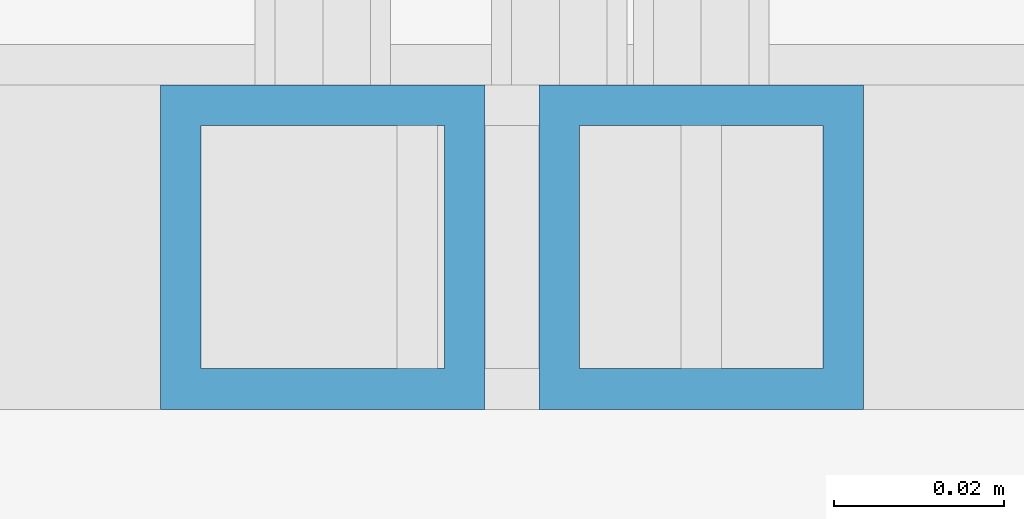
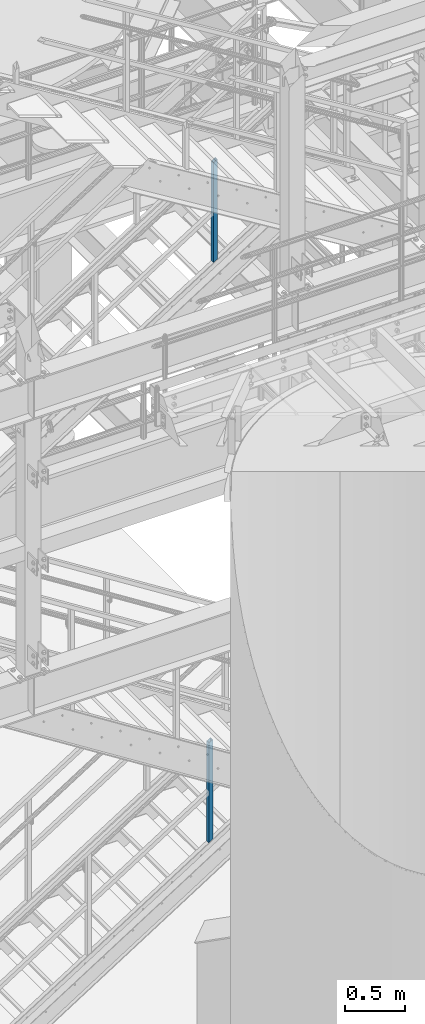
# One storey, part 626 of 1876: 2 columns, 2 elements without a shape of their own.
"""IFC2X3 building model written with IfcOpenShell, lengths in millimetres."""

from ifc_helpers import new_model, si_unit, frame, origin_with_axes, place, context, subcontext, project, spatial, faceted_brep, material, type_object, element, aggregate, save


model = new_model("IFC2X3")

# Units and contexts
model_context = context("Model", 3, precision=1e-05, world=origin_with_axes())
body_context = subcontext(model_context, "Body", "Model", "MODEL_VIEW")
ifc_project = project(units=[si_unit("LENGTHUNIT", "METRE", prefix="MILLI"), si_unit("AREAUNIT", "SQUARE_METRE"), si_unit("VOLUMEUNIT", "CUBIC_METRE"), si_unit("MASSUNIT", "GRAM", prefix="KILO"), si_unit("TIMEUNIT", "SECOND"), si_unit("PLANEANGLEUNIT", "RADIAN"), si_unit("SOLIDANGLEUNIT", "STERADIAN"), si_unit("THERMODYNAMICTEMPERATUREUNIT", "DEGREE_CELSIUS"), si_unit("LUMINOUSINTENSITYUNIT", "LUMEN")], contexts=[model_context])

# Site, building, storey
site_placement = place(None, origin_with_axes())
site = spatial("IfcSite", under=ifc_project, at=site_placement, CompositionType="ELEMENT")
building_placement = place(site_placement, origin_with_axes())
building = spatial("IfcBuilding", under=site, at=building_placement, Name="Undefined", CompositionType="ELEMENT")
storey_placement = place(building_placement, origin_with_axes())
storey = spatial("IfcBuildingStorey", under=building, at=storey_placement, Name="Undefined", CompositionType="ELEMENT", Elevation=0.0)

# Assembly, column
assembly_1_placement = place(storey_placement, origin_with_axes())
assembly_1 = element("IfcElementAssembly", 1, at=assembly_1_placement, inside=storey, Name="RAIL", AssemblyPlace="NOTDEFINED", PredefinedType="RIGID_FRAME")
ifc_material = material()
column_type = type_object("IfcColumnType", Name="HSS1-1/2X1-1/2X3/16", PredefinedType="NOTDEFINED")
column_1_placement = place(assembly_1_placement, frame((5080.00000001265, -5734.05000114554, 1689.80893524023), z_axis=(-1.0, 0.0, 0.0), x_axis=(0.0, 0.0, 1.0)))
column_1 = element("IfcColumn", 2, at=column_1_placement, type_object=column_type, material=ifc_material, Name="POST", ObjectType="HSS1-1/2X1-1/2X3/16", context=body_context, shape_type="Brep", body=[
    faceted_brep([(1026.24509902744, -19.0500000000002, -19.0499992349996), (1026.24509902744, 19.0499992349996, -19.0499992349996), (1002.07429278916, 19.0499992349996, 19.0499992349996), (1002.07429278916, -19.0499992349996, 19.0499992349996), (1023.22374824753, -14.2874994260001, -14.2874994260001), (1005.09564356916, -14.2874994260001, 14.2874994260001), (1005.09564356916, 14.2874994260001, 14.2874994260001), (1023.22374824753, 14.2874994260001, -14.2874994260001), (-12.0854031191318, 19.0499992349996, 19.0499992349996), (-12.0854031191318, -19.0499992349996, 19.0499992349996), (12.0854031191295, -19.0499992349996, -19.0499992349996), (12.0854031191295, 19.0499992349996, -19.0499992349996), (-9.06405233919031, 14.2874994260001, 14.2874994260001), (-9.06405233919031, -14.2874994260001, 14.2874994260001), (9.06405233918804, -14.2874994260001, -14.2874994260001), (9.06405233918804, 14.2874994260001, -14.2874994260001)], [[[0, 1, 2, 3], [4, 5, 6, 7]], [[8, 9, 3, 2]], [[9, 10, 0, 3]], [[10, 11, 1, 0]], [[11, 8, 2, 1]], [[10, 9, 8, 11], [12, 13, 14, 15]], [[15, 14, 4, 7]], [[12, 15, 7, 6]], [[13, 12, 6, 5]], [[14, 13, 5, 4]]]),
])
aggregate(assembly_1, [column_1])

assembly_2_placement = place(storey_placement, origin_with_axes())
assembly_2 = element("IfcElementAssembly", 3, at=assembly_2_placement, inside=storey, Name="RAIL", AssemblyPlace="NOTDEFINED", PredefinedType="RIGID_FRAME")
column_2_placement = place(assembly_2_placement, frame((5124.44999535509, -5734.05000114554, 7574.77276638744), z_axis=(-1.0, 0.0, 0.0), x_axis=(0.0, 0.0, 1.0)))
column_2 = element("IfcColumn", 4, at=column_2_placement, type_object=column_type, material=ifc_material, Name="POST", ObjectType="HSS1-1/2X1-1/2X3/16", context=body_context, shape_type="Brep", body=[
    faceted_brep([(1026.23571825648, -19.0500000000002, -19.0499992349996), (1026.23571825648, 19.0499992349996, -19.0499992349996), (1001.99026470106, 19.0499992349996, 19.0499992349996), (1001.99026470106, -19.0499992349996, 19.0499992349996), (1023.20503656197, -14.2874994260001, -14.2874994260001), (1005.02094639574, -14.2874994260001, 14.2874994260001), (1005.02094639574, 14.2874994260001, 14.2874994260001), (1023.20503656197, 14.2874994260001, -14.2874994260001), (-12.1227267776903, 19.0499992349996, 19.0499992349996), (-12.1227267776903, -19.0499992349996, 19.0499992349996), (12.1227267777067, -19.0499992349996, -19.0499992349996), (12.1227267777067, 19.0499992349996, -19.0499992349996), (-9.09204508310631, 14.2874994260001, 14.2874994260001), (-9.09204508310631, -14.2874994260001, 14.2874994260001), (9.09204508312268, -14.2874994260001, -14.2874994260001), (9.09204508312268, 14.2874994260001, -14.2874994260001)], [[[0, 1, 2, 3], [4, 5, 6, 7]], [[8, 9, 3, 2]], [[9, 10, 0, 3]], [[10, 11, 1, 0]], [[11, 8, 2, 1]], [[10, 9, 8, 11], [12, 13, 14, 15]], [[15, 14, 4, 7]], [[12, 15, 7, 6]], [[13, 12, 6, 5]], [[14, 13, 5, 4]]]),
])
aggregate(assembly_2, [column_2])

save(model, "model.ifc")
